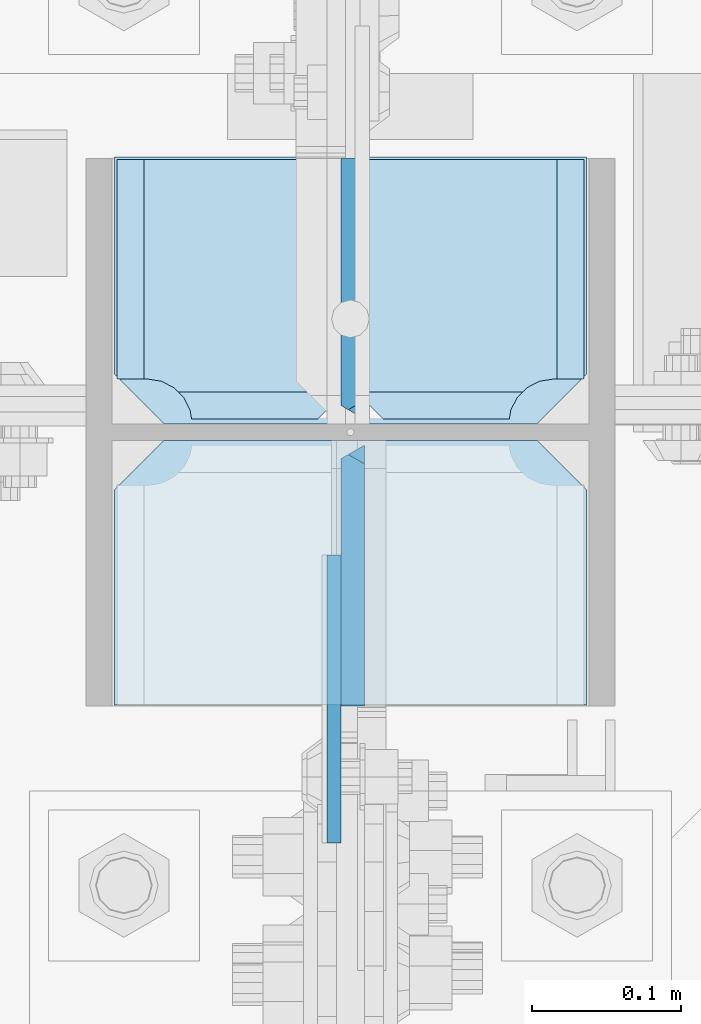
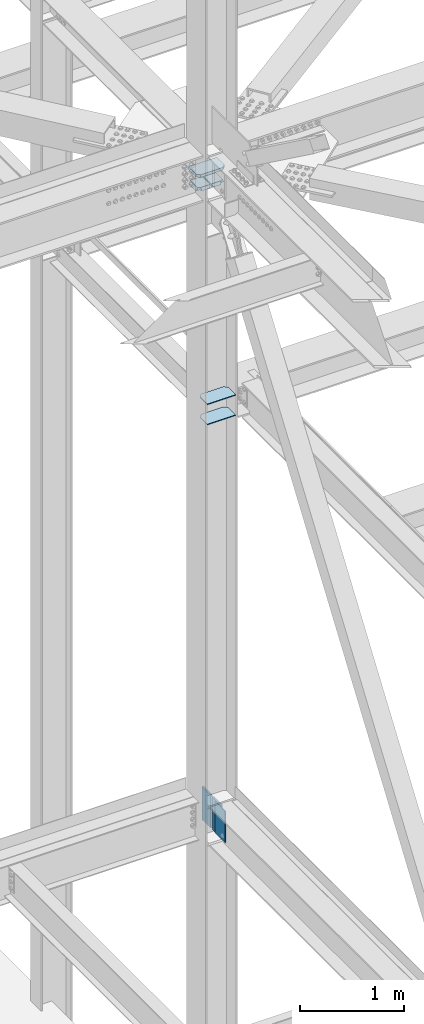
# One storey, part 3196 of 3843: 8 plates, 1 element without a shape of its own.
"""IFC2X3 building model written with IfcOpenShell, lengths in millimetres."""

from ifc_helpers import new_model, si_unit, frame, origin_with_axes, place, context, subcontext, project, spatial, faceted_brep, material, type_object, element, aggregate, save


model = new_model("IFC2X3")

# Units and contexts
model_context = context("Model", 3, precision=1e-05, world=origin_with_axes())
body_context = subcontext(model_context, "Body", "Model", "MODEL_VIEW")
ifc_project = project(units=[si_unit("LENGTHUNIT", "METRE", prefix="MILLI"), si_unit("AREAUNIT", "SQUARE_METRE"), si_unit("VOLUMEUNIT", "CUBIC_METRE"), si_unit("MASSUNIT", "GRAM", prefix="KILO"), si_unit("TIMEUNIT", "SECOND"), si_unit("PLANEANGLEUNIT", "RADIAN"), si_unit("SOLIDANGLEUNIT", "STERADIAN"), si_unit("THERMODYNAMICTEMPERATUREUNIT", "DEGREE_CELSIUS"), si_unit("LUMINOUSINTENSITYUNIT", "LUMEN")], contexts=[model_context])

# Site, building, storey
site_placement = place(None, origin_with_axes())
site = spatial("IfcSite", under=ifc_project, at=site_placement, CompositionType="ELEMENT")
building_placement = place(site_placement, origin_with_axes())
building = spatial("IfcBuilding", under=site, at=building_placement, Name="Undefined", CompositionType="ELEMENT")
storey_placement = place(building_placement, origin_with_axes())
storey = spatial("IfcBuildingStorey", under=building, at=storey_placement, Name="Undefined", CompositionType="ELEMENT", Elevation=0.0)

# Assembly, plates
assembly_placement = place(storey_placement, origin_with_axes())
assembly = element("IfcElementAssembly", 1, at=assembly_placement, inside=storey, Name="COLUMN", AssemblyPlace="NOTDEFINED", PredefinedType="RIGID_FRAME")
ifc_material = material(Name="STEEL/A572-50")
plate_type_1 = type_object("IfcPlateType", PredefinedType="NOTDEFINED")
plate_1_placement = place(assembly_placement, frame((77171.55, 25610.34375, 39308.0875), z_axis=(-1.0, 0.0, 0.0), x_axis=(0.0, -1.0, 0.0)))
plate_1 = element("IfcPlate", 2, at=plate_1_placement, type_object=plate_type_1, material=ifc_material, Name="PLATE", context=body_context, shape_type="Brep", body=[
    faceted_brep([(0.0, -4.76249999999709, 33.3375015258789), (0.0, -4.76249999999709, 284.162498474121), (0.0, 4.76249999999709, 284.162498474121), (0.0, 4.76249999999709, 33.3375015258789), (33.3375015258789, -4.76249999999709, 317.5), (33.3375015258789, 4.76249999999709, 317.5), (177.800003051758, -4.76249999999709, 317.5), (177.800003051758, 4.76249999999709, 317.5), (177.800000000003, -4.76249999999709, -1.45519152283669e-11), (177.800000000003, 4.76249999999709, -1.45519152283669e-11), (33.3375015258789, -4.76249999999709, 0.0), (33.3375015258789, 4.76249999999709, 0.0)], [[[0, 1, 2, 3]], [[1, 4, 5, 2]], [[4, 6, 7, 5]], [[6, 8, 9, 7]], [[8, 10, 11, 9]], [[10, 0, 3, 11]], [[5, 7, 9, 11, 3, 2]], [[10, 8, 6, 4, 1, 0]]]),
])
plate_2_placement = place(assembly_placement, frame((77171.55, 25610.34375, 39546.2125), z_axis=(-1.0, 0.0, 0.0), x_axis=(0.0, -1.0, 0.0)))
plate_2 = element("IfcPlate", 3, at=plate_2_placement, type_object=plate_type_1, material=ifc_material, Name="PLATE", context=body_context, shape_type="Brep", body=[
    faceted_brep([(0.0, -4.76249999999709, 33.3375015258789), (0.0, -4.76249999999709, 284.162498474121), (0.0, 4.76249999999709, 284.162498474121), (0.0, 4.76249999999709, 33.3375015258789), (33.3375015258789, -4.76249999999709, 317.5), (33.3375015258789, 4.76249999999709, 317.5), (177.800003051758, -4.76249999999709, 317.5), (177.800003051758, 4.76249999999709, 317.5), (177.800000000003, -4.76249999999709, -1.45519152283669e-11), (177.800000000003, 4.76249999999709, -1.45519152283669e-11), (33.3375015258789, -4.76249999999709, 0.0), (33.3375015258789, 4.76249999999709, 0.0)], [[[0, 1, 2, 3]], [[1, 4, 5, 2]], [[4, 6, 7, 5]], [[6, 8, 9, 7]], [[8, 10, 11, 9]], [[10, 0, 3, 11]], [[5, 7, 9, 11, 3, 2]], [[10, 8, 6, 4, 1, 0]]]),
])
plate_type_2 = type_object("IfcPlateType", PredefinedType="NOTDEFINED")
plate_3_placement = place(assembly_placement, frame((77001.6875, 25339.6750004117, 34763.075), z_axis=(0.0, 0.0, -1.0), x_axis=(0.0, 1.0, 0.0)))
plate_3 = element("IfcPlate", 4, at=plate_3_placement, type_object=plate_type_2, material=ifc_material, Name="PLATE", context=body_context, shape_type="Brep", body=[
    faceted_brep([(0.0, -4.76249999999709, 0.0), (8.90977389644831e-08, -4.76249999999709, 371.474998644393), (8.90977389644831e-08, 4.76249999999709, 371.474998644393), (0.0, 4.76249999999709, 0.0), (193.675000089086, -4.76249999999709, 371.474998644226), (193.675000089086, 4.76249999999709, 371.474998644226), (193.674999999996, -4.76249999999709, 0.0), (193.674999999996, 4.76249999999709, 0.0)], [[[0, 1, 2, 3]], [[1, 4, 5, 2]], [[4, 6, 7, 5]], [[6, 0, 3, 7]], [[5, 7, 3, 2]], [[6, 4, 1, 0]]]),
])
plate_type_3 = type_object("IfcPlateType", PredefinedType="NOTDEFINED")
plate_4_placement = place(assembly_placement, frame((77014.3875, 25610.34375, 34391.6), z_axis=(0.0, -0.707106781186682, 0.707106781186413), x_axis=(0.0, -0.707106781186548, -0.707106781186548)))
plate_4 = element("IfcPlate", 5, at=plate_4_placement, type_object=plate_type_3, material=ifc_material, Name="PLATE", context=body_context, shape_type="Brep", body=[
    faceted_brep([(13.4703841830633, -7.9375, 3.98162703275011), (-258.690864485565, -7.9375, 276.14287571052), (-262.672491524594, -3.06102270410338, 276.142875710538), (-262.672491524769, 7.9375, 267.162619527516), (4.49012799373304, 7.9375, 0.0), (13.4703841824085, -3.06102271161217, -3.63797880709171e-12), (22.4506403697887, 7.9375, -1.81898940354586e-11), (137.510171880771, 7.93750000091677, 115.059531510957), (131.029230271015, -7.9375, 121.540473120702), (-141.13201839559, -7.93749999998545, 393.701721800519), (-147.612960006612, 7.9375, 400.182663411669), (-262.672491524412, 7.9375, 285.123131893843), (111.691935371156, 7.9375, 140.877768029306), (111.691935371156, -7.9375, 140.877768029306), (-121.794723493209, 7.9375, 374.364426898479), (-121.794723493209, -7.9375, 374.364426898479)], [[[0, 1, 2, 3, 4, 5]], [[6, 7, 8, 0, 5]], [[9, 10, 11, 2, 1]], [[6, 5, 4]], [[12, 13, 8, 7]], [[14, 15, 13, 12]], [[8, 13, 15, 9, 1, 0]], [[11, 3, 2]], [[14, 12, 7, 6, 4, 3, 11, 10]], [[15, 14, 10, 9]]]),
])
plate_5_placement = place(assembly_placement, frame((77014.3875, 25621.45625, 34391.6), z_axis=(0.0, 0.707106781186548, 0.707106781186548), x_axis=(5.70000238222118e-08, 0.707106781186546, -0.707106781186546)))
plate_5 = element("IfcPlate", 6, at=plate_5_placement, type_object=plate_type_3, material=ifc_material, Name="PLATE", context=body_context, shape_type="Brep", body=[
    faceted_brep([(4.49012799309094, -7.9375, 7.27595761418343e-12), (-262.67249152472, -7.9375, 267.162619524512), (-262.67249152453, 3.06102198078588, 276.142875119622), (-258.690863883758, 7.9375000243308, 276.142875124584), (13.470384184775, 7.9375, 3.98162703046546), (13.4703841731916, 3.06102272879798, -7.27595761418343e-12), (131.029230272985, 7.9375, 121.540473118737), (137.510171884061, -7.9375, 115.059531507664), (22.4506403026729, -7.93750001103617, 0.0), (-262.672491524336, -7.9375, 285.123130726228), (-147.612959422382, -7.9375, 400.182662828171), (-141.132017801337, 7.93750074267155, 393.701721206991)], [[[0, 1, 2, 3, 4, 5]], [[6, 7, 8, 5, 4]], [[9, 10, 11, 3, 2]], [[8, 0, 5]], [[11, 10, 7, 6]], [[1, 0, 8, 7, 10, 9]], [[9, 2, 1]], [[11, 6, 4, 3]]]),
])
plate_type_4 = type_object("IfcPlateType", PredefinedType="NOTDEFINED")
plate_6_placement = place(assembly_placement, frame((77173.1375, 25621.45625, 41941.75), z_axis=(-1.0, 0.0, 0.0), x_axis=(0.0, 1.0, 0.0)))
plate_6 = element("IfcPlate", 7, at=plate_6_placement, type_object=plate_type_4, material=ifc_material, Name="PLATE", context=body_context, shape_type="Brep", body=[
    faceted_brep([(30.1625003814697, -15.875, 21.5053709991334), (30.1625003814697, 15.875, 3.1744999523653), (177.799999999999, 15.875, 3.1744999523653), (177.799999999999, -15.875, 21.5053709991334), (17.7290728964945, -9.33382680522482, 48.2144734940957), (21.505620998505, -15.875, 44.4379253920924), (21.505620998505, -15.875, 153.987500000003), (19.0499992370605, -11.6217383418407, 153.987500000003), (3.17474995173325, 15.875, 138.112250714679), (3.17474995173325, 15.875, 53.4721674798493), (9.32072521071677, 5.22985860508925, 52.4987406282016), (19.0499992370605, 15.875, 153.987500000003), (177.799999999999, -15.875, 153.987500000003), (177.799999999999, 15.875, 153.987500000003), (30.1625003814697, -15.875, 23.8124980926514), (30.1625003814697, 15.875, 23.8124980926514), (28.6862425355503, -15.875, 33.1332233033609), (28.6862425355503, 15.875, 33.1332233033609), (24.401975401448, -15.875, 41.5415709891386), (24.401975401448, 15.875, 41.5415709891386), (17.7290728964945, 15.875, 48.2144734940957), (9.32072521071677, 15.875, 52.4987406282016)], [[[0, 1, 2, 3]], [[4, 5, 6, 7, 8, 9, 10]], [[11, 8, 7]], [[12, 13, 11, 7, 6]], [[13, 12, 3, 2]], [[14, 15, 1, 0]], [[14, 16, 17, 15]], [[16, 18, 19, 17]], [[20, 19, 18, 5, 4]], [[21, 20, 4, 10]], [[21, 10, 9]], [[11, 13, 2, 1, 15, 17, 19, 20, 21, 9, 8]], [[12, 6, 5, 18, 16, 14, 0, 3]]]),
])
plate_7_placement = place(assembly_placement, frame((76852.4625, 25621.45625, 41941.75), z_axis=(1.0, 0.0, 0.0), x_axis=(0.0, 1.0, 0.0)))
plate_7 = element("IfcPlate", 8, at=plate_7_placement, type_object=plate_type_4, material=ifc_material, Name="PLATE", context=body_context, shape_type="Brep", body=[
    faceted_brep([(177.799999999999, 15.875, 21.5053709990898), (177.799999999999, -15.875, 3.17449995232164), (30.1625003814697, -15.875, 3.17449995232164), (30.1625003814697, 15.875, 21.5053709990898), (21.505620998505, 15.875, 153.987500000003), (21.505620998505, 15.875, 44.4379253920924), (17.7290728964945, 9.33382680522482, 48.2144734940957), (9.32072521071677, -5.22985860508925, 52.4987406282016), (3.17474995173325, -15.875, 53.4721674798493), (3.17474995173325, -15.875, 138.112250714679), (19.0499992370605, 11.6217383418407, 153.987500000003), (19.0499992370605, -15.875, 153.987500000003), (177.799999999999, -15.875, 153.987500000003), (177.799999999999, 15.875, 153.987500000003), (30.1625003814697, -15.875, 23.8124980926514), (30.1625003814697, 15.875, 23.8124980926514), (28.6862425355503, -15.875, 33.1332233033609), (28.6862425355503, 15.875, 33.1332233033609), (24.401975401448, -15.875, 41.5415709891386), (24.401975401448, 15.875, 41.5415709891386), (17.7290728964945, -15.875, 48.2144734940957), (9.32072521071677, -15.875, 52.4987406282016)], [[[0, 1, 2, 3]], [[4, 5, 6, 7, 8, 9, 10]], [[11, 10, 9]], [[11, 12, 13, 4, 10]], [[13, 12, 1, 0]], [[14, 15, 3, 2]], [[14, 16, 17, 15]], [[16, 18, 19, 17]], [[19, 18, 20, 6, 5]], [[20, 21, 7, 6]], [[21, 8, 7]], [[15, 17, 19, 5, 4, 13, 0, 3]], [[21, 20, 18, 16, 14, 2, 1, 12, 11, 9, 8]]]),
])
plate_type_5 = type_object("IfcPlateType", PredefinedType="NOTDEFINED")
plate_8_placement = place(assembly_placement, frame((77171.55, 25800.84375, 42108.4375000006), z_axis=(-1.0, 0.0, 0.0), x_axis=(0.0, -1.0, 0.0)))
plate_8 = element("IfcPlate", 9, at=plate_8_placement, type_object=plate_type_5, material=ifc_material, Name="PLATE", context=body_context, shape_type="Brep", body=[
    faceted_brep([(0.0, -15.875, 0.0), (0.0, -15.875, 317.5), (0.0, 15.875, 317.5), (0.0, 15.875, 0.0), (146.049998474133, -15.875, 317.5), (146.049998474133, 15.875, 317.5), (179.387500000012, -15.875, 284.162498474121), (179.387500000012, 15.875, 284.162498474121), (179.387500000012, -15.875, 33.3375015258789), (179.387500000012, 15.875, 33.3375015258789), (146.049998474133, -15.875, 0.0), (146.049998474133, 15.875, 0.0)], [[[0, 1, 2, 3]], [[1, 4, 5, 2]], [[4, 6, 7, 5]], [[6, 8, 9, 7]], [[8, 10, 11, 9]], [[10, 0, 3, 11]], [[5, 7, 9, 11, 3, 2]], [[10, 8, 6, 4, 1, 0]]]),
])
aggregate(assembly, [plate_3, plate_4, plate_6, plate_7, plate_1, plate_2, plate_5, plate_8])

save(model, "model.ifc")
